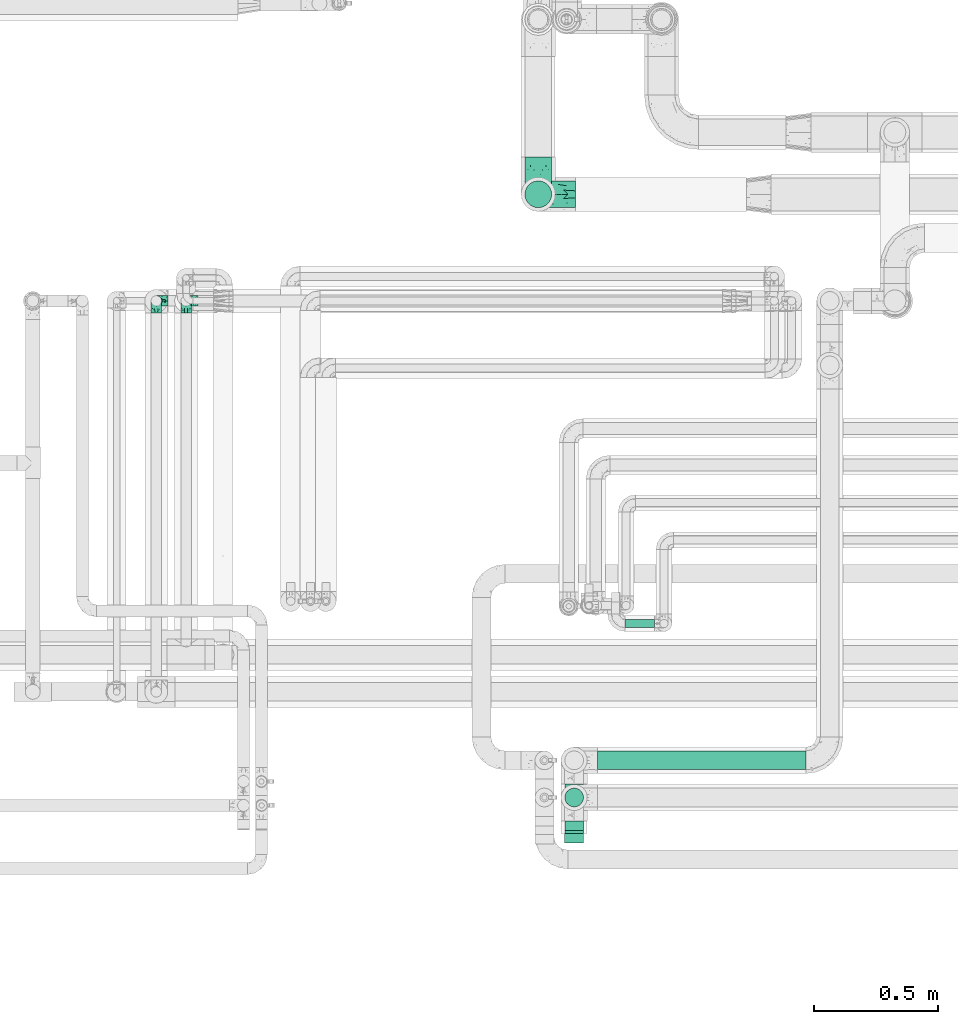
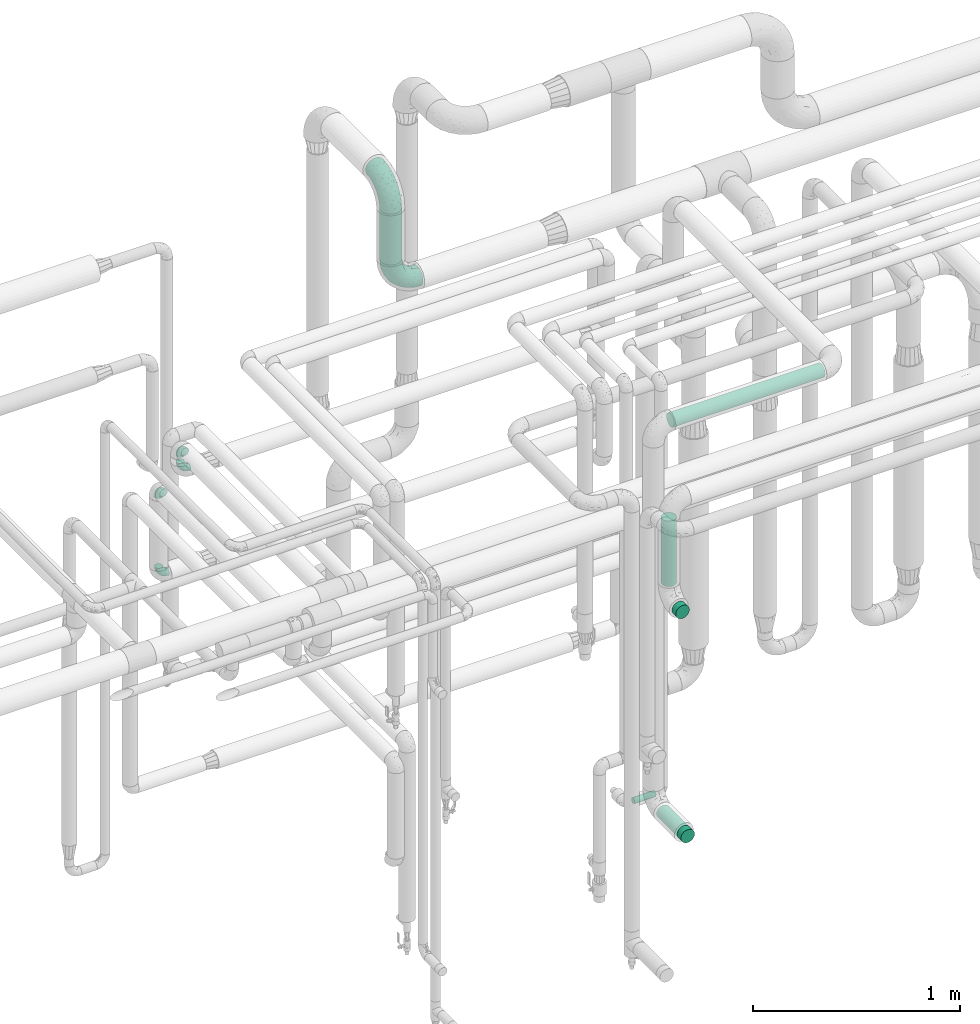
# One storey, part 701 of 827: 8 flow fittings, 5 flow segments.
"""IFC2X3 building model written with IfcOpenShell, lengths in millimetres."""

from ifc_helpers import new_model, entity, si_unit, converted_unit, derived_unit, direction, frame, origin, origin_2d_with_axis, place, context, subcontext, project, spatial, circle, extrude, faceted_brep, source, transform, mapped, material, type_object, type_shapes, element, save


model = new_model("IFC2X3")

# Units and contexts
model_context = context("Model", 3, precision=0.01, world=origin(), true_north=direction((6.12303176911189e-17, 1.0)))
body_context = subcontext(model_context, "Body", "Model", "MODEL_VIEW")
ifc_project = project(units=[si_unit("LENGTHUNIT", "METRE", prefix="MILLI"), si_unit("AREAUNIT", "SQUARE_METRE"), si_unit("VOLUMEUNIT", "CUBIC_METRE"), converted_unit("PLANEANGLEUNIT", "DEGREE", entity("IfcRatioMeasure", 0.0174532925199433), si_unit("PLANEANGLEUNIT", "RADIAN"), dimensions=[0, 0, 0, 0, 0, 0, 0]), si_unit("MASSUNIT", "GRAM", prefix="KILO"), derived_unit("MASSDENSITYUNIT", [(si_unit("MASSUNIT", "GRAM", prefix="KILO"), 1), (si_unit("LENGTHUNIT", "METRE"), -3)]), derived_unit("MOMENTOFINERTIAUNIT", [(si_unit("LENGTHUNIT", "METRE"), 4)]), si_unit("TIMEUNIT", "SECOND"), si_unit("FREQUENCYUNIT", "HERTZ"), si_unit("THERMODYNAMICTEMPERATUREUNIT", "DEGREE_CELSIUS"), derived_unit("THERMALTRANSMITTANCEUNIT", [(si_unit("MASSUNIT", "GRAM", prefix="KILO"), 1), (si_unit("THERMODYNAMICTEMPERATUREUNIT", "KELVIN"), -1), (si_unit("TIMEUNIT", "SECOND"), -3)]), derived_unit("VOLUMETRICFLOWRATEUNIT", [(si_unit("LENGTHUNIT", "METRE"), 3), (si_unit("TIMEUNIT", "SECOND"), -1)]), derived_unit("MASSFLOWRATEUNIT", [(si_unit("MASSUNIT", "GRAM", prefix="KILO"), 1), (si_unit("TIMEUNIT", "SECOND"), -1)]), derived_unit("ROTATIONALFREQUENCYUNIT", [(si_unit("TIMEUNIT", "SECOND"), -1)]), si_unit("ELECTRICCURRENTUNIT", "AMPERE"), si_unit("ELECTRICVOLTAGEUNIT", "VOLT"), si_unit("POWERUNIT", "WATT"), si_unit("FORCEUNIT", "NEWTON", prefix="KILO"), si_unit("ILLUMINANCEUNIT", "LUX"), si_unit("LUMINOUSFLUXUNIT", "LUMEN"), si_unit("LUMINOUSINTENSITYUNIT", "CANDELA"), derived_unit("USERDEFINED", [(si_unit("MASSUNIT", "GRAM", prefix="KILO"), -1), (si_unit("LENGTHUNIT", "METRE"), -2), (si_unit("TIMEUNIT", "SECOND"), 3), (si_unit("LUMINOUSFLUXUNIT", "LUMEN"), 1)]), derived_unit("LINEARVELOCITYUNIT", [(si_unit("LENGTHUNIT", "METRE"), 1), (si_unit("TIMEUNIT", "SECOND"), -1)]), si_unit("PRESSUREUNIT", "PASCAL"), derived_unit("USERDEFINED", [(si_unit("LENGTHUNIT", "METRE"), -2), (si_unit("MASSUNIT", "GRAM", prefix="KILO"), 1), (si_unit("TIMEUNIT", "SECOND"), -2)]), derived_unit("LINEARFORCEUNIT", [(si_unit("MASSUNIT", "GRAM", prefix="KILO"), 1), (si_unit("LENGTHUNIT", "METRE"), 1), (si_unit("TIMEUNIT", "SECOND"), -2), (si_unit("LENGTHUNIT", "METRE"), -1)]), derived_unit("PLANARFORCEUNIT", [(si_unit("MASSUNIT", "GRAM", prefix="KILO"), 1), (si_unit("LENGTHUNIT", "METRE"), 1), (si_unit("TIMEUNIT", "SECOND"), -2), (si_unit("LENGTHUNIT", "METRE"), -2)])], contexts=[model_context])

# Site, building, storey
site_placement = place(None, origin())
site = spatial("IfcSite", under=ifc_project, at=site_placement, CompositionType="ELEMENT")
building_placement = place(site_placement, origin())
building = spatial("IfcBuilding", under=site, at=building_placement, CompositionType="ELEMENT")
storey_placement = place(building_placement, frame((0.0, 0.0, 28200.0)))
storey = spatial("IfcBuildingStorey", under=building, at=storey_placement, Name="08", CompositionType="ELEMENT", Elevation=28200.0)

# Flow segments
pipe_segment_type_1 = type_object("IfcPipeSegmentType", PredefinedType="NOTDEFINED")
flow_segment_1_placement = place(storey_placement, frame((55555.45, 17874.5, 3049.96)))
element("IfcFlowSegment", 1, at=flow_segment_1_placement, inside=storey, type_object=pipe_segment_type_1, context=body_context, shape_type="SweptSolid", body=[
    extrude(circle(Radius=54.0, at=origin_2d_with_axis()), frame((55.6, 55.6, 0.0), z_axis=(0.0, 0.0, 1.0), x_axis=(-1.0, 0.0, 0.0)), (0.0, 0.0, 1.0), 299.782089013237),
])
pipe_segment_type_2 = type_object("IfcPipeSegmentType", PredefinedType="NOTDEFINED")
flow_segment_2_placement = place(storey_placement, frame((55850.84, 15606.86, 3360.65)))
element("IfcFlowSegment", 2, at=flow_segment_2_placement, inside=storey, type_object=pipe_segment_type_2, context=body_context, shape_type="SweptSolid", body=[
    extrude(circle(Radius=37.75, at=origin_2d_with_axis()), frame((0.0, 39.35, 39.35), z_axis=(1.0, 0.0, 0.0), x_axis=(0.0, 1.0, 0.0)), (0.0, 0.0, 1.0), 841.541968197392),
])
flow_segment_3_placement = place(storey_placement, frame((55961.13, 16179.59, 766.4)))
element("IfcFlowSegment", 3, at=flow_segment_3_placement, inside=storey, type_object=pipe_segment_type_2, context=body_context, shape_type="SweptSolid", body=[
    extrude(circle(Radius=16.75, at=origin_2d_with_axis()), frame((0.0, 18.35, 18.35), z_axis=(1.0, 0.0, 0.0), x_axis=(0.0, 1.0, 0.0)), (0.0, 0.0, 1.0), 119.000000000016),
])
flow_segment_4_placement = place(storey_placement, frame((55716.5, 15351.2, 1145.65)))
element("IfcFlowSegment", 4, at=flow_segment_4_placement, inside=storey, type_object=pipe_segment_type_2, context=body_context, shape_type="SweptSolid", body=[
    extrude(circle(Radius=37.75, at=origin_2d_with_axis()), frame((39.35, 0.0, 39.35), z_axis=(0.0, 1.0, 0.0), x_axis=(-1.0, 0.0, 0.0)), (0.0, 0.0, 1.0), 200.000000000009),
])
flow_segment_5_placement = place(storey_placement, frame((55716.5, 15456.86, 2570.0)))
element("IfcFlowSegment", 5, at=flow_segment_5_placement, inside=storey, type_object=pipe_segment_type_2, context=body_context, shape_type="SweptSolid", body=[
    extrude(circle(Radius=37.75, at=origin_2d_with_axis()), frame((39.35, 39.35, 0.0)), (0.0, 0.0, 1.0), 384.999999999969),
])

# Flow fittings
ifc_material = material()
pipe_fitting_type_1 = type_object("IfcPipeFittingType", Name="ADSK_1", PredefinedType="NOTDEFINED", material=ifc_material)
shared_shape_1 = source(origin(), body_context, "Body", "SweptSolid", [
    extrude(circle(Radius=38.05, at=origin_2d_with_axis()), frame((0.0, 0.0, 0.0), z_axis=(1.0, 0.0, 0.0), x_axis=(0.0, 1.0, 0.0)), (0.0, 0.0, 1.0), 38.0000000000003),
])
type_shapes(pipe_fitting_type_1, [shared_shape_1])
for number, where, z_axis, x_axis, name in (
    (6, (55755.84, 15401.2, 2475.0), (-1.0, 0.0, 0.0), (0.0, -1.0, 0.0), "ADSK_1"),
    (7, (55755.84, 15351.2, 1185.0), (0.0, 0.0, 1.0), (0.0, -1.0, 0.0), "ADSK_1"),
):
    element("IfcFlowFitting", number, at=place(storey_placement, frame(where, z_axis=z_axis, x_axis=x_axis)), inside=storey, type_object=pipe_fitting_type_1, material=ifc_material, Name=name, ObjectType="ADSK_1", context=body_context, shape_type="MappedRepresentation", body=[
        mapped(shared_shape_1, transform((0.0, 0.0, 0.0), scale=1.0)),
    ])
pipe_fitting_type_2 = type_object("IfcPipeFittingType", Name="ADSK_2", PredefinedType="NOTDEFINED", material=ifc_material)
shared_shape_2 = source(origin(), body_context, "Body", "Brep", [
    faceted_brep([(-150.0, 13.98, -52.16), (-150.0, 0.0, -54.0), (-150.0, -13.98, -52.16), (-150.0, -27.0, -46.77), (-150.0, -38.18, -38.18), (-150.0, -46.77, -27.0), (-150.0, -52.16, -13.98), (-150.0, -54.0, 0.0), (-150.0, -52.16, 13.98), (-150.0, -46.77, 27.0), (-150.0, -38.18, 38.18), (-150.0, -27.0, 46.77), (-150.0, -13.98, 52.16), (-150.0, 0.0, 54.0), (-150.0, 13.98, 52.16), (-150.0, 27.0, 46.77), (-150.0, 38.18, 38.18), (-150.0, 46.77, 27.0), (-150.0, 52.16, 13.98), (-150.0, 54.0, 0.0), (-150.0, 52.16, -13.98), (-150.0, 46.77, -27.0), (-150.0, 38.18, -38.18), (-150.0, 27.0, -46.77), (-46.77, 150.0, -27.0), (-52.16, 150.0, -13.98), (-54.0, 150.0, 0.0), (-52.16, 150.0, 13.98), (-46.77, 150.0, 27.0), (-38.18, 150.0, 38.18), (-27.0, 150.0, 46.77), (-13.98, 150.0, 52.16), (0.0, 150.0, 54.0), (13.98, 150.0, 52.16), (27.0, 150.0, 46.77), (38.18, 150.0, 38.18), (46.77, 150.0, 27.0), (52.16, 150.0, 13.98), (54.0, 150.0, 0.0), (52.16, 150.0, -13.98), (46.77, 150.0, -27.0), (38.18, 150.0, -38.18), (27.0, 150.0, -46.77), (13.98, 150.0, -52.16), (0.0, 150.0, -54.0), (-13.98, 150.0, -52.16), (-27.0, 150.0, -46.77), (-38.18, 150.0, -38.18), (-23.02, 116.05, 50.71), (-10.79, 106.96, 53.83), (-99.79, -44.6, 17.82), (-104.61, -48.89, 0.0), (-111.52, -18.45, 48.95), (-64.27, -5.9, 46.22), (-79.66, 4.7, 52.78), (-22.81, -9.49, 0.0), (-44.33, -22.22, 14.35), (-61.49, -33.8, 0.0), (-111.02, -40.26, 31.0), (-106.96, 10.79, 53.83), (-75.79, 19.35, 54.0), (-83.79, 28.63, 52.71), (-6.35, 6.35, 9.57), (22.22, 44.33, 14.35), (-8.95, 8.95, 21.66), (-70.7, -34.05, 19.37), (-77.79, -39.89, 9.53), (-98.78, -28.03, 40.91), (-35.45, -0.96, 36.82), (-24.08, 24.08, 46.13), (-116.99, -5.61, 53.23), (-84.48, 39.18, 49.64), (-116.05, 23.02, 50.71), (28.03, 98.78, 40.91), (-30.84, 79.95, 52.7), (-19.51, 75.72, 54.0), (-52.23, 125.53, 22.23), (-63.5, 102.33, 17.08), (-52.58, 23.63, 53.15), (-23.76, 41.59, 51.45), (-36.39, 47.25, 53.91), (-58.7, 120.33, 0.0), (-125.53, 52.23, 22.23), (-102.33, 63.5, 17.08), (-120.33, 58.7, 0.0), (-59.32, 99.83, 27.68), (-79.36, 79.36, 20.15), (-75.61, 75.61, 30.15), (-114.52, 47.22, 34.83), (-126.22, 33.98, 43.81), (-93.57, 72.33, 0.0), (-47.51, 113.57, 34.88), (18.45, 111.52, 48.95), (5.61, 116.99, 53.23), (48.89, 104.61, 0.0), (44.6, 99.79, 17.82), (37.15, 71.79, 11.16), (5.9, 64.27, 46.22), (-4.7, 79.66, 52.78), (35.09, 74.65, 20.78), (40.26, 111.02, 31.0), (26.44, 65.11, 28.6), (-65.6, -16.94, 39.27), (-65.11, -26.44, 28.6), (-81.51, 81.51, 9.56), (-72.33, 93.57, 0.0), (9.49, 22.81, 0.0), (-35.64, -11.82, 24.43), (-34.23, 124.56, 43.88), (-43.22, 94.57, 45.11), (-69.02, 56.15, 47.3), (-59.26, 74.56, 43.5), (-78.28, 61.88, 39.9), (18.71, 65.93, 37.87), (0.96, 35.45, 36.82), (-59.2, 87.93, 36.27), (33.8, 61.49, 0.0), (-97.33, 42.02, 44.99), (-99.65, 59.35, 27.78), (-56.16, 9.04, 50.42), (11.82, 35.64, 24.43), (-49.6, 72.87, 48.67), (-34.04, 93.29, 49.78), (-57.05, 51.22, 52.06), (-124.56, 34.23, -43.88), (-98.78, -28.03, -40.91), (-79.66, 4.7, -52.78), (-116.99, -5.61, -53.23), (-106.96, 10.79, -53.83), (-99.83, 59.32, -27.68), (-113.57, 47.51, -34.88), (-125.53, 52.23, -22.23), (-116.05, 23.02, -50.71), (-79.95, 30.84, -52.7), (-47.22, 114.52, -34.83), (-102.33, 63.5, -17.08), (40.26, 111.02, -31.0), (-81.51, 81.51, -9.56), (-52.23, 125.53, -22.23), (-94.57, 43.22, -45.11), (-64.27, -5.9, -46.22), (-35.45, -0.96, -36.82), (-65.93, -18.71, -37.87), (-99.79, -44.6, -17.82), (-47.25, 36.39, -53.91), (-75.72, 19.51, -54.0), (-39.18, 84.48, -49.64), (-23.02, 116.05, -50.71), (-28.63, 83.79, -52.71), (-111.02, -40.26, -31.0), (-10.79, 106.96, -53.83), (-19.35, 75.79, -54.0), (-44.33, -22.22, -14.35), (-8.95, 8.95, -21.66), (-6.35, 6.35, -9.57), (-71.79, -37.15, -11.16), (-61.88, 78.28, -39.9), (-74.56, 59.26, -43.5), (-87.93, 59.2, -36.27), (-74.65, -35.09, -20.78), (-65.11, -26.44, -28.6), (0.96, 35.45, -36.82), (-63.5, 102.33, -17.08), (-79.36, 79.36, -20.15), (18.45, 111.52, -48.95), (5.9, 64.27, -46.22), (-4.7, 79.66, -52.78), (-75.61, 75.61, -30.15), (-33.98, 126.22, -43.81), (5.61, 116.99, -53.23), (-23.63, 52.58, -53.15), (-41.59, 23.76, -51.45), (22.22, 44.33, -14.35), (-56.15, 69.02, -47.3), (28.03, 98.78, -40.91), (39.89, 77.79, -9.53), (34.05, 70.7, -19.37), (-111.52, -18.45, -48.95), (44.6, 99.79, -17.82), (26.44, 65.11, -28.6), (11.82, 35.64, -24.43), (16.94, 65.6, -39.27), (-42.02, 97.33, -44.99), (-59.35, 99.65, -27.78), (-24.08, 24.08, -46.13), (-9.04, 56.16, -50.42), (-35.64, -11.82, -24.43), (-72.87, 49.6, -48.67), (-93.29, 34.04, -49.78), (-51.22, 57.05, -52.06)], [[[0, 1, 2, 3, 4, 5, 6, 7, 8, 9, 10, 11, 12, 13, 14, 15, 16, 17, 18, 19, 20, 21, 22, 23]], [[24, 25, 26, 27, 28, 29, 30, 31, 32, 33, 34, 35, 36, 37, 38, 39, 40, 41, 42, 43, 44, 45, 46, 47]], [[31, 48, 49]], [[50, 8, 51]], [[52, 53, 54]], [[8, 50, 9]], [[8, 7, 51]], [[55, 56, 57]], [[58, 9, 50]], [[59, 60, 61]], [[62, 63, 64]], [[65, 66, 56]], [[11, 10, 67]], [[53, 68, 69]], [[67, 52, 11]], [[70, 59, 13]], [[71, 72, 61]], [[73, 35, 34]], [[74, 75, 49]], [[72, 15, 14]], [[13, 59, 14]], [[76, 27, 77]], [[12, 70, 13]], [[78, 79, 80]], [[27, 81, 77]], [[18, 82, 83]], [[72, 14, 59]], [[84, 19, 18]], [[85, 86, 87]], [[88, 16, 89]], [[84, 83, 90]], [[84, 18, 83]], [[15, 89, 16]], [[85, 91, 76]], [[92, 73, 34]], [[49, 32, 31]], [[93, 33, 32]], [[31, 30, 48]], [[94, 95, 96]], [[94, 37, 95]], [[73, 92, 97]], [[98, 93, 49]], [[11, 52, 12]], [[36, 95, 37]], [[99, 100, 101]], [[95, 36, 100]], [[63, 96, 99]], [[100, 36, 35]], [[102, 53, 67]], [[38, 37, 94]], [[92, 34, 33]], [[103, 67, 58]], [[81, 27, 26]], [[104, 105, 90]], [[106, 62, 55]], [[9, 58, 10]], [[91, 29, 28]], [[77, 81, 105]], [[107, 103, 65]], [[49, 48, 74]], [[83, 86, 104]], [[108, 91, 109]], [[16, 88, 17]], [[110, 111, 112]], [[113, 114, 101]], [[108, 30, 29]], [[113, 97, 114]], [[112, 111, 115]], [[66, 51, 57]], [[63, 106, 116]], [[74, 80, 75]], [[82, 18, 17]], [[76, 28, 27]], [[115, 91, 85]], [[112, 88, 117]], [[118, 83, 82]], [[58, 50, 65]], [[67, 10, 58]], [[35, 73, 100]], [[101, 100, 73]], [[53, 52, 67]], [[70, 52, 54]], [[102, 103, 68]], [[119, 78, 54]], [[93, 92, 33]], [[98, 79, 97]], [[98, 97, 92]], [[97, 69, 114]], [[56, 55, 62]], [[56, 107, 65]], [[96, 63, 116]], [[63, 99, 120]], [[108, 48, 30]], [[121, 74, 122]], [[61, 72, 59]], [[89, 72, 117]], [[107, 68, 103]], [[64, 120, 114]], [[69, 68, 114]], [[64, 114, 68]], [[122, 74, 48]], [[74, 123, 80]], [[123, 61, 60]], [[80, 60, 78]], [[49, 93, 32]], [[92, 93, 98]], [[52, 70, 12]], [[59, 70, 54]], [[59, 54, 60]], [[123, 110, 71]], [[78, 60, 54]], [[123, 60, 80]], [[119, 54, 53]], [[78, 119, 79]], [[97, 79, 69]], [[98, 80, 79]], [[53, 69, 119]], [[79, 119, 69]], [[91, 108, 29]], [[108, 109, 122]], [[85, 76, 77]], [[91, 28, 76]], [[86, 85, 77]], [[115, 85, 87]], [[112, 115, 87]], [[109, 91, 115]], [[112, 87, 118]], [[112, 117, 110]], [[71, 110, 117]], [[122, 109, 121]], [[17, 88, 82]], [[118, 87, 86]], [[82, 88, 118]], [[112, 118, 88]], [[80, 98, 75]], [[98, 49, 75]], [[111, 110, 121]], [[115, 111, 109]], [[72, 89, 15]], [[88, 89, 117]], [[72, 71, 117]], [[123, 71, 61]], [[77, 105, 104]], [[118, 86, 83]], [[83, 104, 90]], [[77, 104, 86]], [[63, 62, 106]], [[56, 62, 64]], [[56, 64, 107]], [[68, 107, 64]], [[58, 65, 103]], [[66, 65, 50]], [[51, 66, 50]], [[56, 66, 57]], [[94, 96, 116]], [[99, 96, 95]], [[100, 99, 95]], [[99, 101, 120]], [[114, 120, 101]], [[64, 63, 120]], [[103, 102, 67]], [[68, 53, 102]], [[101, 73, 113]], [[97, 113, 73]], [[108, 122, 48]], [[111, 121, 109]], [[110, 123, 121]], [[74, 121, 123]], [[22, 124, 23]], [[125, 4, 3]], [[126, 127, 128]], [[129, 130, 131]], [[132, 133, 128]], [[128, 1, 0]], [[19, 84, 20]], [[47, 134, 24]], [[90, 135, 84]], [[40, 136, 41]], [[105, 137, 90]], [[131, 20, 135]], [[138, 25, 24]], [[139, 124, 130]], [[130, 22, 21]], [[140, 141, 142]], [[5, 143, 6]], [[133, 144, 145]], [[51, 7, 6]], [[146, 147, 148]], [[143, 5, 149]], [[150, 151, 148]], [[57, 152, 55]], [[153, 154, 152]], [[20, 84, 135]], [[143, 51, 6]], [[143, 155, 51]], [[156, 157, 158]], [[127, 2, 1]], [[159, 149, 160]], [[0, 23, 132]], [[141, 161, 153]], [[162, 163, 137]], [[42, 164, 43]], [[164, 165, 166]], [[44, 150, 45]], [[163, 167, 129]], [[25, 81, 26]], [[0, 132, 128]], [[162, 25, 138]], [[147, 46, 45]], [[47, 168, 134]], [[43, 169, 44]], [[170, 171, 144]], [[81, 25, 162]], [[46, 168, 47]], [[106, 172, 116]], [[150, 147, 45]], [[173, 157, 156]], [[42, 174, 164]], [[55, 154, 106]], [[174, 42, 41]], [[169, 150, 44]], [[175, 172, 176]], [[125, 3, 177]], [[133, 145, 128]], [[178, 40, 39]], [[179, 174, 136]], [[38, 94, 39]], [[152, 155, 159]], [[149, 5, 4]], [[178, 39, 94]], [[175, 94, 116]], [[40, 178, 136]], [[177, 3, 2]], [[179, 176, 180]], [[125, 177, 140]], [[162, 105, 81]], [[181, 165, 174]], [[160, 142, 141]], [[131, 21, 20]], [[158, 130, 129]], [[156, 134, 182]], [[183, 162, 138]], [[4, 125, 149]], [[160, 149, 125]], [[136, 178, 176]], [[174, 41, 136]], [[127, 177, 2]], [[126, 171, 140]], [[126, 140, 177]], [[140, 184, 141]], [[165, 164, 174]], [[169, 164, 166]], [[181, 179, 161]], [[185, 170, 166]], [[155, 152, 57]], [[152, 159, 186]], [[172, 106, 154]], [[172, 180, 176]], [[124, 132, 23]], [[187, 133, 188]], [[148, 147, 150]], [[168, 147, 182]], [[161, 184, 165]], [[186, 141, 153]], [[161, 179, 180]], [[141, 184, 161]], [[188, 133, 132]], [[133, 189, 144]], [[189, 148, 151]], [[144, 151, 170]], [[128, 127, 1]], [[177, 127, 126]], [[164, 169, 43]], [[150, 169, 166]], [[150, 166, 151]], [[189, 173, 146]], [[170, 151, 166]], [[189, 151, 144]], [[185, 166, 165]], [[170, 185, 171]], [[140, 171, 184]], [[126, 144, 171]], [[165, 184, 185]], [[171, 185, 184]], [[130, 124, 22]], [[124, 139, 188]], [[129, 131, 135]], [[130, 21, 131]], [[163, 129, 135]], [[158, 129, 167]], [[156, 158, 167]], [[139, 130, 158]], [[156, 167, 183]], [[156, 182, 173]], [[146, 173, 182]], [[188, 139, 187]], [[24, 134, 138]], [[183, 167, 163]], [[138, 134, 183]], [[156, 183, 134]], [[144, 126, 145]], [[126, 128, 145]], [[157, 173, 187]], [[158, 157, 139]], [[147, 168, 46]], [[134, 168, 182]], [[147, 146, 182]], [[189, 146, 148]], [[135, 90, 137]], [[183, 163, 162]], [[162, 137, 105]], [[135, 137, 163]], [[152, 154, 55]], [[172, 154, 153]], [[51, 155, 57]], [[159, 155, 143]], [[149, 159, 143]], [[159, 160, 186]], [[141, 186, 160]], [[153, 152, 186]], [[172, 153, 180]], [[161, 180, 153]], [[136, 176, 179]], [[175, 176, 178]], [[94, 175, 178]], [[172, 175, 116]], [[160, 125, 142]], [[140, 142, 125]], [[179, 181, 174]], [[161, 165, 181]], [[124, 188, 132]], [[157, 187, 139]], [[173, 189, 187]], [[133, 187, 189]]]),
])
type_shapes(pipe_fitting_type_2, [shared_shape_2])
for number, where, z_axis, x_axis, name in (
    (8, (55611.05, 17930.1, 2899.96), (0.0, 1.0, 0.0), (-1.0, 0.0, 0.0), "ADSK_2"),
    (9, (55611.05, 17930.1, 3499.74), (-1.0, 0.0, 0.0), (0.0, 0.0, 1.0), "ADSK_2"),
):
    element("IfcFlowFitting", number, at=place(storey_placement, frame(where, z_axis=z_axis, x_axis=x_axis)), inside=storey, type_object=pipe_fitting_type_2, material=ifc_material, Name=name, ObjectType="ADSK_2", context=body_context, shape_type="MappedRepresentation", body=[
        mapped(shared_shape_2, transform((0.0, 0.0, 0.0), scale=1.0)),
    ])
pipe_fitting_type_3 = type_object("IfcPipeFittingType", Name="ADSK_1", PredefinedType="NOTDEFINED", material=ifc_material)
shared_shape_3 = source(origin(), body_context, "Body", "Brep", [
    faceted_brep([(-48.0, 10.6, -18.36), (-48.0, 5.49, -20.48), (-48.0, 0.0, -21.2), (-48.0, -5.49, -20.48), (-48.0, -10.6, -18.36), (-48.0, -14.99, -14.99), (-48.0, -18.36, -10.6), (-48.0, -20.48, -5.49), (-48.0, -21.2, 0.0), (-48.0, -20.48, 5.49), (-48.0, -18.36, 10.6), (-48.0, -14.99, 14.99), (-48.0, -10.6, 18.36), (-48.0, -5.49, 20.48), (-48.0, 0.0, 21.2), (-48.0, 5.49, 20.48), (-48.0, 10.6, 18.36), (-48.0, 14.99, 14.99), (-48.0, 18.36, 10.6), (-48.0, 20.48, 5.49), (-48.0, 21.2, 0.0), (-48.0, 20.48, -5.49), (-48.0, 18.36, -10.6), (-48.0, 14.99, -14.99), (0.0, 48.0, -21.2), (-5.49, 48.0, -20.48), (-10.6, 48.0, -18.36), (-14.99, 48.0, -14.99), (-18.36, 48.0, -10.6), (-20.48, 48.0, -5.49), (-21.2, 48.0, 0.0), (-20.48, 48.0, 5.49), (-18.36, 48.0, 10.6), (-14.99, 48.0, 14.99), (-10.6, 48.0, 18.36), (-5.49, 48.0, 20.48), (0.0, 48.0, 21.2), (5.49, 48.0, 20.48), (10.6, 48.0, 18.36), (14.99, 48.0, 14.99), (18.36, 48.0, 10.6), (20.48, 48.0, 5.49), (21.2, 48.0, 0.0), (20.48, 48.0, -5.49), (18.36, 48.0, -10.6), (14.99, 48.0, -14.99), (10.6, 48.0, -18.36), (5.49, 48.0, -20.48), (-35.25, -16.22, 12.01), (-34.76, -18.57, 0.0), (-20.87, -12.37, 10.9), (-31.49, -11.78, 15.9), (-37.0, -2.58, 20.86), (-33.89, 3.62, 21.15), (-31.81, -18.14, 6.76), (-5.78, 5.78, 17.67), (-19.42, -4.1, 17.86), (-9.6, -3.39, 13.73), (-35.44, -7.73, 19.13), (11.78, 31.49, 15.9), (-5.93, -5.46, 6.95), (-18.45, -13.78, 5.46), (-10.29, -8.43, 0.0), (-24.6, 0.55, 20.62), (-37.28, 17.94, 13.81), (-33.38, 22.85, 9.59), (-41.46, 20.06, 8.75), (-29.51, 20.45, 15.16), (-15.04, 10.79, 21.13), (-7.08, 16.98, 20.93), (-8.39, 23.51, 21.15), (-40.86, 13.03, 17.26), (-8.05, 41.26, 19.83), (-3.21, 35.97, 21.14), (8.53, 19.66, 14.74), (4.1, 19.42, 17.86), (-37.72, 22.66, 4.78), (-37.07, 8.58, 19.98), (-13.0, 5.43, 19.97), (-3.78, 13.93, 19.7), (3.02, 8.69, 13.43), (-2.27, -0.05, 10.65), (6.22, 6.99, 7.09), (-22.25, 34.6, 9.45), (18.14, 31.81, 6.76), (16.22, 35.25, 12.01), (12.37, 20.87, 10.9), (7.73, 35.44, 19.13), (-21.52, -15.93, 0.0), (2.58, 37.0, 20.86), (18.57, 34.76, 0.0), (13.78, 18.45, 5.46), (15.93, 21.52, 0.0), (-20.03, -8.54, 14.9), (-28.6, 28.6, 5.16), (-24.79, 34.6, 0.0), (-34.6, 24.79, 0.0), (-22.81, 37.41, 4.68), (-23.36, 26.33, 14.79), (-13.68, 37.05, 17.49), (-17.72, 38.12, 13.73), (-26.25, 27.3, 11.24), (-9.71, 32.34, 20.14), (-17.26, 25.6, 18.71), (-26.33, 9.99, 20.77), (-24.06, 6.05, 21.2), (-25.02, 15.46, 19.56), (-24.3, 20.72, 17.57), (-31.95, 15.23, 17.8), (-13.53, 24.7, 20.21), (-17.6, 17.6, 20.6), (-0.55, 24.6, 20.62), (-11.41, -7.48, 10.43), (0.93, -0.93, 0.0), (8.43, 10.29, 0.0), (-11.41, -7.48, -10.43), (-20.1, -8.84, -14.66), (-9.6, -3.39, -13.73), (7.73, 35.44, -19.13), (4.1, 19.42, -17.86), (-0.55, 24.6, -20.62), (-38.12, 17.72, -13.73), (-37.05, 13.68, -17.49), (-32.34, 9.71, -20.14), (-41.26, 8.05, -19.83), (-37.41, 22.81, -4.68), (-23.51, 8.39, -21.15), (-35.97, 3.21, -21.14), (-28.6, 28.6, -5.16), (-31.81, -18.14, -6.76), (-18.45, -13.78, -5.46), (-25.6, 17.26, -18.71), (-19.42, -4.1, -17.86), (-17.94, 37.28, -13.81), (-22.85, 33.38, -9.59), (-20.06, 41.46, -8.75), (-31.49, -11.78, -15.9), (-35.25, -16.22, -12.01), (8.53, 19.66, -14.74), (11.78, 31.49, -15.9), (-9.99, 26.33, -20.77), (-6.05, 24.06, -21.2), (-10.79, 15.04, -21.13), (-37.0, -2.58, -20.86), (-16.98, 7.08, -20.93), (-5.43, 13.0, -19.97), (-13.93, 3.78, -19.7), (-20.87, -12.37, -10.9), (-26.33, 23.36, -14.79), (-22.66, 37.72, -4.78), (13.78, 18.45, -5.46), (18.14, 31.81, -6.76), (-15.46, 25.02, -19.56), (-20.72, 24.3, -17.57), (16.22, 35.25, -12.01), (-13.03, 40.86, -17.26), (-8.58, 37.07, -19.98), (2.58, 37.0, -20.86), (-3.62, 33.89, -21.15), (-34.6, 22.25, -9.45), (6.22, 6.99, -7.09), (-20.45, 29.51, -15.16), (-35.44, -7.73, -19.13), (12.37, 20.87, -10.9), (-27.3, 26.25, -11.24), (-15.23, 31.95, -17.8), (-24.7, 13.53, -20.21), (-24.6, 0.55, -20.62), (-5.78, 5.78, -17.67), (-17.6, 17.6, -20.6), (3.02, 8.69, -13.43), (-5.93, -5.46, -6.95), (-2.27, -0.05, -10.65)], [[[0, 1, 2, 3, 4, 5, 6, 7, 8, 9, 10, 11, 12, 13, 14, 15, 16, 17, 18, 19, 20, 21, 22, 23]], [[24, 25, 26, 27, 28, 29, 30, 31, 32, 33, 34, 35, 36, 37, 38, 39, 40, 41, 42, 43, 44, 45, 46, 47]], [[10, 48, 11]], [[9, 8, 49]], [[48, 50, 51]], [[14, 52, 53]], [[10, 54, 48]], [[9, 54, 10]], [[55, 56, 57]], [[51, 12, 11]], [[51, 58, 12]], [[59, 39, 38]], [[60, 61, 62]], [[58, 56, 63]], [[64, 65, 66]], [[67, 65, 64]], [[68, 69, 70]], [[16, 71, 17]], [[13, 52, 14]], [[35, 72, 73]], [[14, 53, 15]], [[17, 64, 18]], [[74, 59, 75]], [[20, 19, 76]], [[66, 19, 18]], [[77, 15, 53]], [[15, 77, 16]], [[69, 78, 79]], [[80, 81, 82]], [[32, 31, 83]], [[84, 85, 86]], [[59, 87, 75]], [[61, 54, 88]], [[36, 89, 37]], [[84, 41, 40]], [[36, 35, 73]], [[90, 41, 84]], [[40, 39, 85]], [[12, 58, 13]], [[85, 84, 40]], [[91, 84, 86]], [[84, 92, 90]], [[87, 38, 37]], [[93, 56, 51]], [[65, 94, 76]], [[94, 95, 96]], [[84, 91, 92]], [[95, 97, 30]], [[98, 99, 100]], [[76, 94, 96]], [[101, 98, 83]], [[100, 99, 33]], [[102, 70, 73]], [[103, 102, 99]], [[94, 97, 95]], [[72, 99, 102]], [[72, 35, 34]], [[34, 33, 99]], [[9, 49, 54]], [[87, 59, 38]], [[104, 105, 68]], [[106, 103, 107]], [[106, 77, 104]], [[71, 64, 17]], [[108, 107, 67]], [[33, 32, 100]], [[109, 103, 110]], [[102, 109, 70]], [[89, 73, 111]], [[50, 48, 54]], [[51, 11, 48]], [[56, 58, 51]], [[88, 54, 49]], [[52, 58, 63]], [[50, 112, 93]], [[56, 55, 78]], [[39, 59, 85]], [[86, 85, 59]], [[89, 87, 37]], [[42, 41, 90]], [[111, 79, 75]], [[111, 75, 87]], [[75, 55, 80]], [[104, 77, 53]], [[71, 77, 108]], [[32, 83, 100]], [[98, 100, 83]], [[99, 98, 103]], [[106, 107, 108]], [[68, 70, 110]], [[111, 73, 70]], [[68, 110, 104]], [[68, 63, 78]], [[57, 93, 112]], [[80, 55, 57]], [[61, 50, 54]], [[80, 82, 86]], [[81, 57, 112]], [[74, 86, 59]], [[60, 113, 82]], [[82, 114, 91]], [[101, 94, 65]], [[97, 94, 83]], [[73, 89, 36]], [[87, 89, 111]], [[58, 52, 13]], [[53, 52, 63]], [[104, 53, 105]], [[106, 104, 110]], [[20, 76, 96]], [[76, 19, 66]], [[103, 106, 110]], [[77, 106, 108]], [[103, 98, 107]], [[67, 107, 98]], [[67, 98, 101]], [[108, 67, 64]], [[53, 63, 105]], [[63, 68, 105]], [[83, 31, 97]], [[30, 97, 31]], [[62, 113, 60]], [[112, 61, 60]], [[61, 88, 62]], [[86, 82, 91]], [[56, 78, 63]], [[114, 82, 113]], [[114, 92, 91]], [[79, 78, 55]], [[75, 79, 55]], [[69, 79, 111]], [[70, 69, 111]], [[78, 69, 68]], [[77, 71, 16]], [[64, 71, 108]], [[64, 66, 18]], [[76, 66, 65]], [[99, 72, 34]], [[73, 72, 102]], [[94, 101, 83]], [[67, 101, 65]], [[75, 80, 74]], [[80, 86, 74]], [[70, 109, 110]], [[102, 103, 109]], [[50, 93, 51]], [[57, 56, 93]], [[61, 112, 50]], [[81, 112, 60]], [[82, 81, 60]], [[80, 57, 81]], [[115, 116, 117]], [[118, 119, 120]], [[121, 122, 23]], [[123, 124, 122]], [[96, 125, 20]], [[123, 126, 127]], [[128, 96, 95]], [[129, 130, 88]], [[123, 122, 131]], [[116, 132, 117]], [[133, 134, 135]], [[0, 124, 1]], [[5, 136, 137]], [[138, 119, 139]], [[129, 88, 49]], [[140, 141, 142]], [[6, 5, 137]], [[46, 118, 47]], [[143, 3, 2]], [[144, 145, 146]], [[6, 129, 7]], [[129, 137, 147]], [[127, 2, 1]], [[148, 122, 121]], [[128, 125, 96]], [[134, 128, 149]], [[95, 149, 128]], [[150, 151, 92]], [[30, 29, 149]], [[152, 131, 153]], [[27, 133, 28]], [[154, 45, 44]], [[136, 5, 4]], [[27, 26, 155]], [[156, 26, 25]], [[24, 157, 158]], [[24, 47, 157]], [[22, 21, 159]], [[160, 150, 114]], [[134, 133, 161]], [[142, 144, 126]], [[46, 139, 118]], [[162, 136, 4]], [[156, 25, 158]], [[1, 124, 127]], [[115, 147, 116]], [[45, 154, 139]], [[139, 46, 45]], [[154, 163, 139]], [[162, 4, 3]], [[42, 90, 43]], [[130, 129, 147]], [[49, 7, 129]], [[43, 151, 44]], [[0, 23, 122]], [[24, 158, 25]], [[136, 162, 132]], [[135, 29, 28]], [[43, 90, 151]], [[164, 148, 159]], [[152, 156, 140]], [[155, 133, 27]], [[165, 153, 161]], [[23, 22, 121]], [[123, 131, 166]], [[123, 166, 126]], [[143, 127, 167]], [[147, 137, 136]], [[8, 7, 49]], [[129, 6, 137]], [[143, 162, 3]], [[167, 146, 132]], [[167, 132, 162]], [[132, 168, 117]], [[44, 151, 154]], [[92, 151, 90]], [[163, 154, 151]], [[119, 118, 139]], [[157, 118, 120]], [[138, 139, 163]], [[119, 168, 145]], [[140, 156, 158]], [[155, 156, 165]], [[22, 159, 121]], [[148, 121, 159]], [[122, 148, 131]], [[152, 153, 165]], [[142, 126, 169]], [[167, 127, 126]], [[142, 169, 140]], [[142, 120, 145]], [[168, 170, 117]], [[160, 171, 172]], [[115, 172, 171]], [[171, 62, 130]], [[119, 170, 168]], [[170, 163, 160]], [[150, 163, 151]], [[113, 171, 160]], [[164, 128, 134]], [[125, 128, 159]], [[127, 143, 2]], [[162, 143, 167]], [[118, 157, 47]], [[158, 157, 120]], [[140, 158, 141]], [[152, 140, 169]], [[30, 149, 95]], [[149, 29, 135]], [[131, 152, 169]], [[156, 152, 165]], [[131, 148, 153]], [[161, 153, 148]], [[161, 148, 164]], [[165, 161, 133]], [[158, 120, 141]], [[120, 142, 141]], [[159, 21, 125]], [[20, 125, 21]], [[115, 130, 147]], [[114, 113, 160]], [[62, 171, 113]], [[62, 88, 130]], [[160, 163, 150]], [[150, 92, 114]], [[119, 145, 120]], [[146, 145, 168]], [[132, 146, 168]], [[144, 146, 167]], [[126, 144, 167]], [[145, 144, 142]], [[156, 155, 26]], [[133, 155, 165]], [[133, 135, 28]], [[149, 135, 134]], [[122, 124, 0]], [[127, 124, 123]], [[128, 164, 159]], [[161, 164, 134]], [[163, 170, 138]], [[170, 119, 138]], [[131, 169, 166]], [[126, 166, 169]], [[147, 136, 116]], [[132, 116, 136]], [[172, 115, 117]], [[130, 115, 171]], [[117, 170, 172]], [[160, 172, 170]]]),
])
type_shapes(pipe_fitting_type_3, [shared_shape_3])
for number, where, z_axis, x_axis, name in (
    (10, (54069.79, 17500.0, 2500.0), (-1.0, 0.0, 0.0), (0.0, 1.0, 0.0), "ADSK_1"),
    (11, (54069.79, 17500.0, 1992.5), (0.0, -1.0, 0.0), (0.0, 0.0, -1.0), "ADSK_1"),
    (12, (54189.79, 17500.0, 2700.0), (-1.0, 0.0, 0.0), (0.0, 1.0, 0.0), "ADSK_1"),
    (13, (54189.79, 17500.0, 2567.5), (0.0, -1.0, 0.0), (0.0, 0.0, -1.0), "ADSK_1"),
):
    element("IfcFlowFitting", number, at=place(storey_placement, frame(where, z_axis=z_axis, x_axis=x_axis)), inside=storey, type_object=pipe_fitting_type_3, material=ifc_material, Name=name, ObjectType="ADSK_1", context=body_context, shape_type="MappedRepresentation", body=[
        mapped(shared_shape_3, transform((0.0, 0.0, 0.0), scale=1.0)),
    ])

save(model, "model.ifc")
